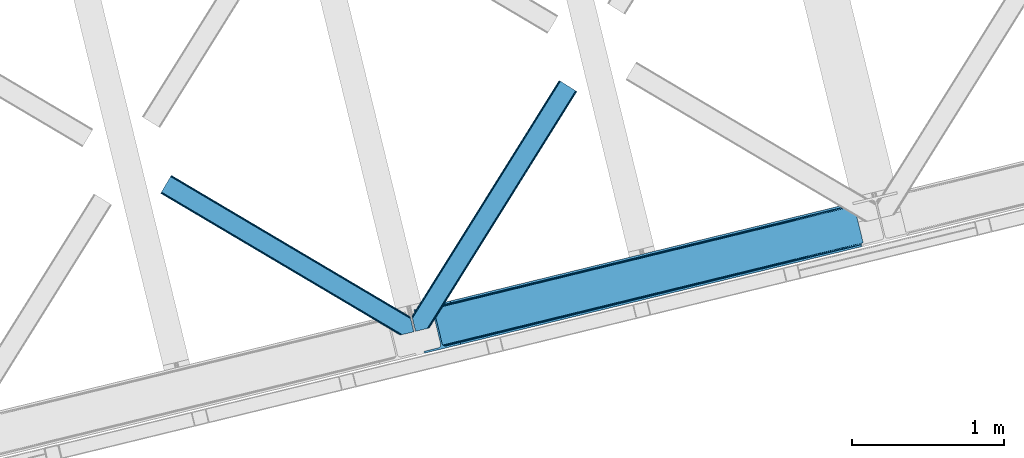
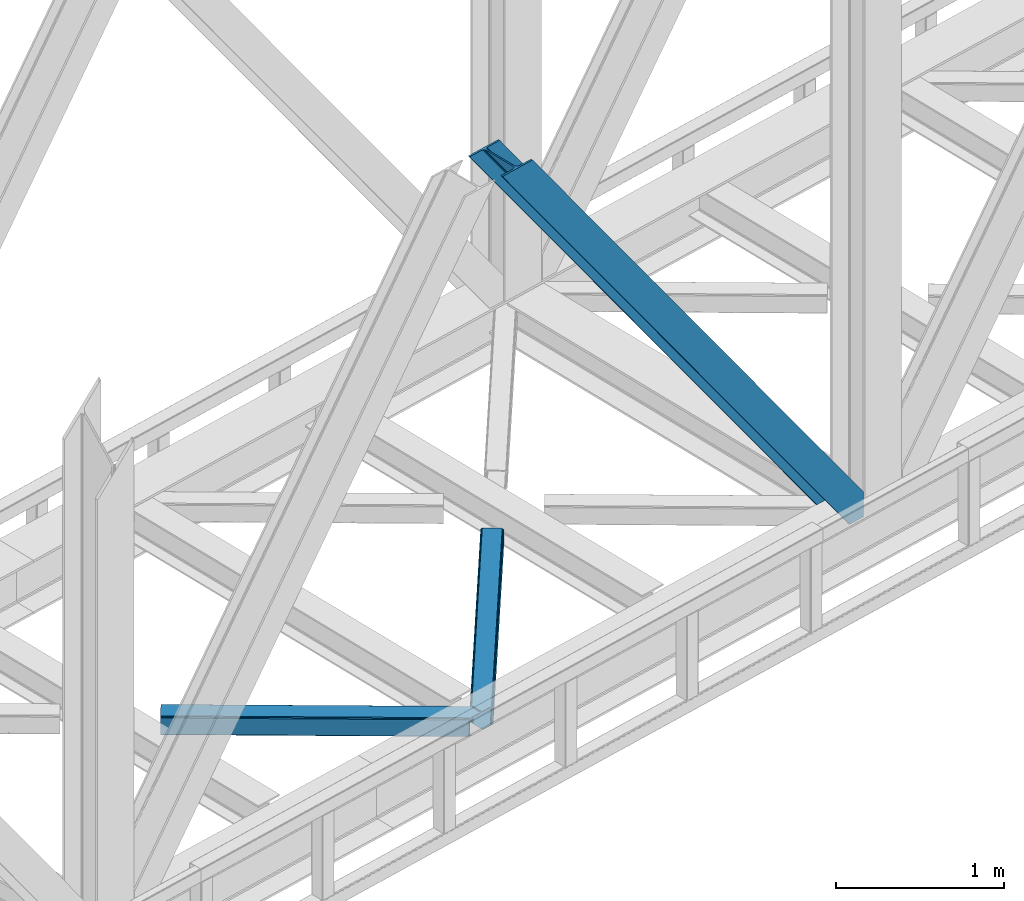
# One storey, part 65 of 92: 3 members.
"""IFC4 building model written with IfcOpenShell, lengths in millimetres."""

from ifc_helpers import new_model, entity, si_unit, converted_unit, derived_unit, direction, frame, origin, place, context, subcontext, project, spatial, triangles, type_object, element, save


model = new_model("IFC4")

# Units and contexts
model_context = context("Model", 3, precision=0.01, world=origin(), true_north=direction((6.12303176911189e-17, 1.0)))
plan_context = context("Plan", 3, precision=0.01, world=origin(), true_north=direction((6.12303176911189e-17, 1.0)))
body_context = subcontext(model_context, "Body", "Model", "MODEL_VIEW")
ifc_project = project(units=[si_unit("LENGTHUNIT", "METRE", prefix="MILLI"), si_unit("AREAUNIT", "SQUARE_METRE"), si_unit("VOLUMEUNIT", "CUBIC_METRE"), converted_unit("PLANEANGLEUNIT", "DEGREE", entity("IfcRatioMeasure", 0.0174532925199433), si_unit("PLANEANGLEUNIT", "RADIAN"), dimensions=[0, 0, 0, 0, 0, 0, 0]), si_unit("MASSUNIT", "GRAM", prefix="KILO"), derived_unit("MASSDENSITYUNIT", [(si_unit("MASSUNIT", "GRAM", prefix="KILO"), 1), (si_unit("LENGTHUNIT", "METRE"), -3)]), derived_unit("MOMENTOFINERTIAUNIT", [(si_unit("LENGTHUNIT", "METRE"), 4)]), si_unit("TIMEUNIT", "SECOND"), si_unit("FREQUENCYUNIT", "HERTZ"), si_unit("THERMODYNAMICTEMPERATUREUNIT", "DEGREE_CELSIUS"), derived_unit("THERMALTRANSMITTANCEUNIT", [(si_unit("MASSUNIT", "GRAM", prefix="KILO"), 1), (si_unit("THERMODYNAMICTEMPERATUREUNIT", "KELVIN"), -1), (si_unit("TIMEUNIT", "SECOND"), -3)]), derived_unit("VOLUMETRICFLOWRATEUNIT", [(si_unit("LENGTHUNIT", "METRE"), 3), (si_unit("TIMEUNIT", "SECOND"), -1)]), derived_unit("MASSFLOWRATEUNIT", [(si_unit("MASSUNIT", "GRAM", prefix="KILO"), 1), (si_unit("TIMEUNIT", "SECOND"), -1)]), derived_unit("ROTATIONALFREQUENCYUNIT", [(si_unit("TIMEUNIT", "SECOND"), -1)]), si_unit("ELECTRICCURRENTUNIT", "AMPERE"), si_unit("ELECTRICVOLTAGEUNIT", "VOLT"), si_unit("POWERUNIT", "WATT"), si_unit("FORCEUNIT", "NEWTON", prefix="KILO"), si_unit("ILLUMINANCEUNIT", "LUX"), si_unit("LUMINOUSFLUXUNIT", "LUMEN"), si_unit("LUMINOUSINTENSITYUNIT", "CANDELA"), derived_unit("USERDEFINED", [(si_unit("MASSUNIT", "GRAM", prefix="KILO"), -1), (si_unit("LENGTHUNIT", "METRE"), -2), (si_unit("TIMEUNIT", "SECOND"), 3), (si_unit("LUMINOUSFLUXUNIT", "LUMEN"), 1)]), derived_unit("LINEARVELOCITYUNIT", [(si_unit("LENGTHUNIT", "METRE"), 1), (si_unit("TIMEUNIT", "SECOND"), -1)]), si_unit("PRESSUREUNIT", "PASCAL"), derived_unit("USERDEFINED", [(si_unit("LENGTHUNIT", "METRE"), -2), (si_unit("MASSUNIT", "GRAM", prefix="KILO"), 1), (si_unit("TIMEUNIT", "SECOND"), -2)]), derived_unit("LINEARFORCEUNIT", [(si_unit("MASSUNIT", "GRAM", prefix="KILO"), 1), (si_unit("LENGTHUNIT", "METRE"), 1), (si_unit("TIMEUNIT", "SECOND"), -2), (si_unit("LENGTHUNIT", "METRE"), -1)]), derived_unit("PLANARFORCEUNIT", [(si_unit("MASSUNIT", "GRAM", prefix="KILO"), 1), (si_unit("LENGTHUNIT", "METRE"), 1), (si_unit("TIMEUNIT", "SECOND"), -2), (si_unit("LENGTHUNIT", "METRE"), -2)])], contexts=[model_context, plan_context])

# Site, building, storey
site_placement = place(None, origin())
site = spatial("IfcSite", under=ifc_project, at=site_placement, CompositionType="ELEMENT")
building_placement = place(site_placement, origin())
building = spatial("IfcBuilding", under=site, at=building_placement, CompositionType="ELEMENT")
storey_placement = place(building_placement, frame((0.0, 0.0, 15900.0)))
storey = spatial("IfcBuildingStorey", under=building, at=storey_placement, Name="05", CompositionType="ELEMENT", Elevation=15900.0)

# Members
member_type_1 = type_object("IfcMemberType", PredefinedType="BRACE")
member_1_placement = place(storey_placement, frame((-20226.16, 12536.45, 3695.0)))
element("IfcMember", 1, at=member_1_placement, inside=storey, type_object=member_type_1, ObjectType="Steel Vertical Brace", PredefinedType="BRACE", context=body_context, shape_type="Tessellation", body=[
    triangles([(2966.89216003418, 730.998403930664, 0.80925292968459), (2967.55374755859, 730.015905761718, 1.10690917968532), (2966.08058166504, 729.656625366211, 0.0), (2964.18534851074, 737.429406738282, 0.0), (2962.43778076172, 728.769470214844, 8.31577148437282), (2962.43778076172, 728.769470214844, 0.0), (2505.8586730957, 612.60679321289, 658.855133056641), (2511.36415100098, 609.932537841796, 662.301434326171), (2954.04410705566, 717.839904785156, 38.6743835449197), (2954.16851806641, 719.764205932617, 32.1678039550752), (2501.4112701416, 617.533236694337, 656.552947998047), (2958.54266967773, 726.957952880859, 14.8293273925774), (2955.07776489258, 722.243124389648, 26.1867736816384), (2955.64168395996, 723.796517944336, 22.4381652832017), (655.166986083983, 156.054428100586, 3289.34108276367), (649.44175415039, 156.069543457032, 3285.27854003906), (213.882293701172, 48.4865753173835, 3911.00081176758), (205.271191406249, 47.7982452392571, 3911.00081176758), (643.935113525389, 158.742636108398, 3281.83223876953), (197.320513916016, 49.8760253906257, 3911.00081176758), (639.488873291015, 163.67024230957, 3279.53005371094), (191.241815185545, 54.4048187255867, 3911.00081176758), (636.782061767579, 170.100082397461, 3278.7231262207), (187.962945556639, 60.6951324462898, 3911.00081176758), (2954.16037902832, 716.45859375, 50.6410949707024), (2517.08822021484, 609.917422485352, 666.36397705078), (2051.60733032227, 496.451092529296, 1322.10767211914), (2045.8832611084, 496.466207885742, 1318.04512939453), (1580.40353393555, 383.001040649415, 1973.78882446289), (1586.12760314941, 382.985925292969, 1977.85369262695), (1114.92264404297, 269.534710693359, 2629.53251953125), (1120.64671325684, 269.519595336915, 2633.59738769531), (2040.37778320312, 499.140463256836, 1314.598828125), (1574.89689331055, 385.675296020509, 1970.34484863281), (1109.41600341797, 272.208966064452, 2626.08854370117), (2035.93154296875, 504.066906738281, 1312.29896850586), (1570.45065307617, 390.601739501953, 1968.04266357422), (1104.96976318359, 277.135409545899, 2623.78635864258), (2498.70445861816, 623.963076782227, 655.74602050781), (2033.22473144531, 510.497909545898, 1311.48971557617), (1567.74384155273, 397.031579589844, 1967.23341064453), (1102.26295166016, 283.566412353515, 2622.97710571289), (2909.00499572754, 963.80047302246, 0.0), (2443.52410583496, 850.335305786133, 655.74602050781), (1978.04437866211, 736.868975830079, 1311.48971557617), (1512.56348876953, 623.40380859375, 1967.23341064453), (1047.08259887695, 509.937478637696, 2622.97710571289), (581.601708984374, 396.471148681641, 3278.7231262207), (132.782592773438, 287.067361450196, 3911.00081176758), (307.434722900391, 71.2909973144524, 3911.00081176758), (2954.16037902832, 716.45859375, 182.433050537107), (2954.3522277832, 715.476095581054, 0.0), (2954.16851806641, 719.764205932617, 0.0), (2954.3522277832, 715.476095581054, 182.495837402341), (2955.64168395996, 723.796517944336, 0.0), (2958.54266967773, 726.957952880859, 0.0), (2957.19391479492, 703.817504882813, 182.495837402341), (310.513604736327, 58.6603729248054, 3911.00081176758), (2957.19391479492, 703.817504882813, 0.0), (2846.09139404297, 676.734274291992, 0.0), (69.8631774902351, 0.0, 3911.00081176758), (2843.01251220703, 689.364898681641, 0.0), (66.7842956542954, 12.6294616699215, 3911.00081176758), (160.336724853514, 35.4338836669922, 3911.00081176758), (2936.56494140625, 712.169320678711, 0.0), (2953.96039123535, 734.936535644531, 0.0), (2953.94178771973, 727.841619873047, 0.0), (177.731011962889, 58.2010986328132, 3911.00081176758), (177.719384765624, 51.108508300782, 3911.00081176758), (2950.63036193847, 721.02459411621, 0.0), (174.403308105469, 44.2891571044929, 3911.00081176758), (2944.52840881348, 715.520278930664, 0.0), (168.299029541016, 38.7860046386722, 3911.00081176758), (2898.78003845215, 961.308764648438, 0.0), (122.550659179688, 284.573327636719, 3911.00081176758), (2872.85952758789, 973.517321777344, 0.0), (2881.47062988281, 974.205651855469, 0.0), (105.242413330077, 297.47021484375, 3911.00081176758), (96.6313110351548, 296.781884765625, 3911.00081176758), (2889.42130737305, 972.127871704102, 0.0), (113.19309082031, 295.392434692383, 3911.00081176758), (2895.49884338379, 967.599078369141, 0.0), (119.276440429687, 290.864804077148, 3911.00081176758), (3.07888183593604, 273.977462768555, 3911.00081176758), (2779.30709838867, 950.712899780274, 0.0), (2776.22821655273, 963.342361450195, 0.0), (0.0, 286.608087158203, 3911.00081176758), (142.21457519531, 306.482455444337, 3911.00081176758), (150.176879882813, 309.834576416015, 3911.00081176758), (136.110296630857, 300.979302978516, 3911.00081176758), (132.798870849609, 294.161114501952, 3911.00081176758), (240.650427246092, 345.268460083007, 3911.00081176758), (243.729309082031, 332.638998413086, 3911.00081176758), (2887.33073730469, 990.425592041016, 182.495837402341), (2887.33073730469, 990.425592041016, 0.0), (2890.45496520996, 977.805432128906, 182.433050537107), (2890.17242431641, 978.767001342774, 182.495837402341), (1522.42102661133, 644.332763671875, 1977.85369262695), (591.459246826173, 417.401266479492, 3289.34108276367), (1056.94013671875, 530.867596435546, 2633.59738769531), (1987.90191650391, 757.799093627929, 1322.10767211914), (2453.38164367676, 871.265423583984, 666.36397705078), (2890.45496520996, 977.805432128906, 50.6410949707024), (2890.17242431641, 978.767001342774, 0.0), (2890.986328125, 976.525277709961, 38.6743835449197), (2892.14904785156, 974.998626708984, 33.1630920410134), (2891.98277893066, 974.875378417968, 0.0), (2893.5687286377, 973.138275146484, 26.4425720214822), (2895.14653930664, 971.973229980469, 22.4381652832017), (2903.46812438965, 970.684936523438, 8.31577148437282), (2903.46812438965, 970.684936523438, 0.0), (2899.17652587891, 970.50122680664, 0.0), (2899.17652587891, 970.50122680664, 14.8293273925774), (2895.14653930664, 971.973229980469, 0.0), (2907.11092529297, 971.573254394531, 0.0), (2444.64961853027, 863.710070800782, 658.855133056641), (2442.96832580566, 857.289532470702, 656.552947998047), (2908.44921569824, 970.755862426759, 0.80925292968459), (2908.58409118652, 971.932534790039, 1.10690917968532), (581.045928955078, 403.426538085938, 3279.53005371094), (582.727221679688, 409.845913696288, 3281.83223876953), (586.385137939451, 414.753753662109, 3285.27854003906), (2448.30753479004, 868.617910766601, 662.301434326171), (1977.48859863281, 743.823202514648, 1312.29896850586), (1512.00770874024, 630.358035278321, 1968.04266357422), (1046.52681884765, 516.891705322265, 2623.78635864258), (1979.16872863769, 750.243740844726, 1314.598828125), (1513.68783874512, 636.778573608399, 1970.34484863281), (1048.20694885254, 523.312243652344, 2626.08854370117), (1982.82664489746, 755.151580810547, 1318.04512939453), (1517.34575500488, 641.686413574218, 1973.78882446289), (1051.8648651123, 528.220083618164, 2629.53251953125)], [[1, 2, 3], [3, 4, 1], [2, 5, 6], [6, 3, 2], [7, 8, 9], [9, 10, 7], [11, 12, 5], [5, 1, 11], [11, 7, 13], [13, 14, 11], [14, 12, 11], [15, 16, 17], [18, 17, 16], [16, 19, 18], [20, 18, 19], [19, 21, 20], [22, 20, 21], [21, 23, 22], [24, 22, 23], [5, 2, 1], [10, 13, 7], [25, 9, 8], [8, 26, 25], [26, 8, 27], [28, 27, 8], [27, 28, 29], [29, 30, 27], [30, 29, 31], [31, 32, 30], [32, 31, 16], [16, 15, 32], [8, 7, 33], [33, 28, 8], [28, 33, 29], [34, 29, 33], [29, 34, 31], [35, 31, 34], [31, 35, 16], [19, 16, 35], [7, 11, 33], [36, 33, 11], [33, 36, 34], [37, 34, 36], [34, 37, 35], [38, 35, 37], [35, 38, 21], [21, 19, 35], [1, 4, 39], [39, 11, 1], [11, 39, 40], [40, 36, 11], [36, 40, 41], [41, 37, 36], [37, 41, 42], [42, 38, 37], [38, 42, 23], [23, 21, 38], [4, 43, 44], [45, 39, 44], [41, 40, 45], [41, 45, 46], [44, 39, 4], [45, 40, 39], [42, 41, 46], [46, 47, 42], [47, 48, 23], [49, 24, 48], [47, 23, 42], [48, 24, 23], [50, 51, 30], [30, 32, 50], [32, 15, 50], [17, 50, 15], [27, 30, 51], [51, 25, 26], [26, 27, 51], [52, 9, 25], [52, 53, 10], [10, 9, 52], [25, 51, 54], [54, 52, 25], [14, 53, 55], [53, 14, 13], [10, 53, 13], [56, 12, 55], [14, 55, 12], [6, 5, 56], [12, 56, 5], [57, 54, 58], [54, 51, 50], [50, 58, 54], [57, 59, 52], [52, 54, 57], [58, 60, 57], [58, 61, 60], [60, 59, 57], [62, 60, 61], [61, 63, 62], [63, 64, 62], [65, 62, 64], [66, 67, 68], [69, 68, 67], [67, 70, 69], [71, 69, 70], [70, 72, 71], [73, 71, 72], [72, 65, 73], [64, 73, 65], [74, 66, 68], [68, 75, 74], [76, 77, 78], [78, 79, 76], [77, 80, 81], [81, 78, 77], [80, 82, 83], [83, 81, 80], [82, 74, 75], [75, 83, 82], [79, 84, 85], [85, 76, 79], [86, 85, 87], [84, 87, 85], [75, 68, 49], [71, 73, 18], [64, 61, 17], [63, 61, 64], [73, 64, 17], [68, 69, 22], [69, 71, 20], [81, 88, 78], [87, 79, 89], [79, 78, 89], [87, 84, 79], [81, 83, 90], [83, 75, 91], [49, 68, 24], [17, 18, 73], [22, 69, 20], [18, 20, 71], [22, 24, 68], [58, 17, 61], [58, 50, 17], [89, 78, 88], [90, 83, 91], [49, 91, 75], [90, 88, 81], [89, 92, 87], [92, 89, 93], [92, 86, 87], [86, 92, 94], [95, 86, 94], [96, 97, 93], [97, 94, 92], [92, 93, 97], [98, 96, 93], [93, 99, 100], [99, 93, 89], [100, 98, 93], [96, 98, 101], [101, 102, 96], [103, 96, 102], [97, 104, 94], [95, 94, 104], [104, 105, 106], [96, 103, 97], [104, 97, 103], [103, 105, 104], [107, 108, 109], [107, 106, 108], [110, 111, 112], [112, 113, 110], [113, 112, 114], [114, 109, 113], [109, 114, 107], [106, 107, 104], [53, 70, 55], [76, 86, 95], [85, 86, 76], [77, 76, 95], [104, 80, 77], [77, 95, 104], [104, 107, 80], [60, 65, 59], [52, 72, 70], [65, 72, 59], [60, 62, 65], [70, 53, 52], [52, 59, 72], [43, 66, 74], [82, 112, 74], [80, 114, 82], [80, 107, 114], [82, 114, 112], [111, 43, 74], [112, 111, 74], [43, 111, 115], [4, 66, 43], [56, 66, 6], [55, 70, 67], [67, 66, 56], [56, 55, 67], [4, 6, 66], [3, 6, 4], [116, 113, 109], [117, 118, 113], [113, 116, 117], [109, 108, 116], [118, 119, 110], [110, 113, 118], [48, 120, 91], [91, 49, 48], [120, 121, 90], [90, 91, 120], [121, 122, 88], [88, 90, 121], [122, 99, 89], [89, 88, 122], [105, 103, 123], [102, 123, 103], [106, 116, 108], [116, 106, 105], [123, 116, 105], [43, 118, 44], [117, 44, 118], [44, 117, 45], [124, 45, 117], [45, 124, 46], [125, 46, 124], [46, 125, 47], [126, 47, 125], [47, 126, 48], [120, 48, 126], [117, 116, 127], [127, 124, 117], [124, 127, 128], [128, 125, 124], [125, 128, 129], [129, 126, 125], [126, 129, 121], [121, 120, 126], [116, 123, 127], [130, 127, 123], [127, 130, 131], [131, 128, 127], [128, 131, 132], [132, 129, 128], [129, 132, 122], [122, 121, 129], [123, 102, 101], [101, 130, 123], [130, 101, 131], [98, 131, 101], [131, 98, 132], [100, 132, 98], [132, 100, 122], [99, 122, 100], [110, 119, 111], [115, 111, 119], [119, 118, 115], [43, 115, 118]]),
])
member_type_2 = type_object("IfcMemberType", PredefinedType="BRACE")
member_2_placement = place(storey_placement, frame((-20238.88, 12681.07, 3510.0)))
element("IfcMember", 2, at=member_2_placement, inside=storey, type_object=member_type_2, ObjectType="Steel Horizontal Brace", PredefinedType="BRACE", context=body_context, shape_type="Tessellation", body=[
    triangles([(986.150271606446, 1647.42851257324, 0.0), (1075.22041625977, 1591.8260925293, 0.0), (119.788037109374, 259.603921508789, 0.0), (154.548706054688, 117.003323364257, 0.0), (115.902227783205, 275.544808959961, 4.52065429687718), (117.571893310549, 268.698715209961, 1.33247680664135), (158.434515380861, 101.062435913085, 4.52065429687718), (156.767175292971, 107.908529663086, 1.33247680664135), (114.825549316407, 275.742471313477, 5.52059326172093), (115.130181884768, 275.922692871094, 5.35316162109666), (158.132208251955, 99.1218566894531, 5.27525939941552), (115.439465332031, 276.107565307617, 5.18107910156323), (158.236853027345, 99.7776306152336, 5.02062377929906), (158.188018798828, 99.4811370849602, 5.13573303222802), (115.54178466797, 276.166864013672, 5.12526855468968), (115.685961914063, 275.921530151367, 4.88574829101708), (158.339172363281, 100.434567260741, 4.76482543945531), (158.032214355469, 98.4928253173821, 5.52059326172093), (1085.71628723145, 1585.27300415039, 5.12526855468968), (1080.90495300293, 1588.28096008301, 1.33247680664135), (1088.93469543457, 1583.26498718262, 10.8028289794929), (114.209307861329, 21.8521545410149, 10.8028289794929), (109.470062255859, 20.6964111328125, 5.52059326172093), (1090.0695098877, 1582.56037902832, 17.5000946044929), (116.062683105469, 22.3044525146488, 17.5000946044929), (6.7507507324226, 102.618154907226, 5.52059326172093), (31.3608764648452, 1.65687561035156, 5.52059326172093), (1090.0695098877, 1582.56037902832, 122.500662231447), (116.062683105469, 22.3044525146488, 122.500662231447), (1088.93469543457, 1583.26498718262, 129.197927856447), (114.209307861329, 21.8521545410149, 129.197927856447), (1085.71628723145, 1585.27300415039, 134.874325561526), (108.935211181641, 20.5673492431633, 134.874325561526), (1080.90495300293, 1588.28096008301, 138.667117309571), (101.042669677736, 18.6430480957024, 138.667117309571), (1075.22041625977, 1591.8260925293, 139.999594116212), (91.7292846679702, 16.3722564697255, 139.999594116212), (980.470385742188, 1650.97480773926, 1.33247680664135), (975.654400634765, 1653.98160095215, 5.12526855468968), (1.68826904297021, 100.410150146485, 10.9621215820334), (972.435992431641, 1655.99078063965, 10.8028289794929), (971.306991577148, 1656.69655151367, 17.5000946044929), (0.239520263672603, 99.7776306152336, 12.5201660156272), (0.0, 100.760128784179, 17.5000946044929), (5.79266967773583, 76.992974853516, 139.999594116212), (986.150271606446, 1647.42851257324, 139.999594116212), (24.5612915039055, 0.0, 139.999594116212), (971.306991577148, 1656.69655151367, 122.500662231447), (0.0, 100.760128784179, 122.500662231447), (980.470385742188, 1650.97480773926, 138.667117309571), (3.57652587890698, 86.088931274413, 138.667117309571), (975.654400634765, 1653.98160095215, 134.874325561526), (1.69524536133031, 93.7989257812496, 134.874325561526), (972.435992431641, 1655.99078063965, 129.197927856447), (0.439508056642808, 98.9509368896488, 129.197927856447), (29.9237548828132, 1.30689697265552, 6.99957275390625), (12.1969299316406, 74.0326904296871, 6.99957275390625), (8.99479980468823, 81.5485107421864, 8.3320495605476), (3.88813476562427, 84.8111022949215, 12.5201660156272), (1069.28589477539, 1595.53400573731, 6.99957275390625), (81.9973205566421, 14.000308227538, 6.99957275390625), (992.090606689453, 1643.72176208496, 6.99957275390625), (981.593572998048, 1650.27485046387, 12.1260040283232), (978.375164794921, 1652.28403015137, 17.8035644531265), (2.75797119140771, 89.4445404052731, 17.8035644531265), (986.409558105468, 1647.2692199707, 8.3320495605476), (977.246163940432, 1652.98980102539, 24.4996673583992), (2.31613769531396, 91.2537322998051, 24.4996673583992), (977.246163940432, 1652.98980102539, 115.501089477541), (2.31613769531396, 91.2537322998051, 115.501089477541), (4.01370849609521, 84.2925292968739, 127.87475280762), (2.75797119140771, 89.4445404052731, 122.196029663086), (5.89266357422093, 76.5813720703118, 131.667544555665), (8.11113281250073, 67.4865783691403, 133.000021362306), (24.5612915039055, 0.0, 133.000021362306), (978.375164794921, 1652.28403015137, 122.196029663086), (981.593572998048, 1650.27485046387, 127.87475280762), (986.409558105468, 1647.2692199707, 131.667544555665), (992.090606689453, 1643.72176208496, 133.000021362306), (1069.28589477539, 1595.53400573731, 133.000021362306), (81.9973205566421, 14.000308227538, 133.000021362306), (1079.78176574707, 1588.9809173584, 12.1260040283232), (1083.0001739502, 1586.9717376709, 17.8035644531265), (1084.12917480469, 1586.2671295166, 24.4996673583992), (1074.96578063965, 1591.98771057129, 8.3320495605476), (1079.78176574707, 1588.9809173584, 127.87475280762), (1084.12917480469, 1586.2671295166, 115.501089477541), (1083.0001739502, 1586.9717376709, 122.196029663086), (1074.96578063965, 1591.98771057129, 131.667544555665), (91.3083801269531, 16.2699371337894, 131.667544555665), (99.2032470703125, 18.1942382812504, 127.87475280762), (104.477343750001, 19.4802062988274, 122.196029663086), (106.32839355469, 19.931341552734, 115.501089477541), (91.3083801269531, 16.2699371337894, 8.3320495605476), (104.477343750001, 19.4802062988274, 17.8035644531265), (99.2032470703125, 18.1942382812504, 12.1260040283232), (106.32839355469, 19.931341552734, 24.4996673583992)], [[1, 2, 3], [4, 3, 2], [5, 3, 4], [3, 5, 6], [4, 7, 5], [7, 4, 8], [9, 10, 11], [10, 12, 13], [13, 14, 10], [12, 15, 16], [16, 17, 12], [16, 5, 7], [7, 17, 16], [17, 13, 12], [14, 11, 10], [11, 18, 9], [19, 14, 13], [13, 20, 19], [13, 17, 20], [17, 7, 20], [7, 8, 20], [21, 22, 18], [18, 19, 21], [14, 19, 11], [18, 11, 19], [22, 23, 18], [21, 24, 25], [25, 22, 21], [2, 20, 4], [8, 4, 20], [23, 26, 18], [23, 27, 26], [9, 18, 26], [24, 28, 29], [29, 25, 24], [28, 30, 29], [31, 29, 30], [30, 32, 31], [33, 31, 32], [32, 34, 33], [35, 33, 34], [34, 36, 35], [37, 35, 36], [38, 6, 5], [5, 39, 38], [5, 15, 39], [40, 41, 9], [41, 39, 15], [42, 41, 40], [40, 43, 42], [43, 44, 42], [9, 26, 40], [38, 1, 6], [3, 6, 1], [36, 45, 37], [36, 46, 45], [45, 47, 37], [48, 42, 44], [44, 49, 48], [46, 50, 51], [51, 45, 46], [50, 52, 53], [53, 51, 50], [52, 54, 55], [55, 53, 52], [54, 48, 49], [49, 55, 54], [27, 56, 57], [26, 57, 58], [57, 26, 27], [59, 40, 26], [26, 58, 59], [43, 40, 59], [60, 57, 61], [60, 62, 57], [57, 56, 61], [63, 64, 65], [65, 59, 63], [66, 63, 59], [62, 66, 58], [58, 57, 62], [59, 58, 66], [64, 67, 68], [68, 65, 64], [67, 69, 68], [70, 68, 69], [71, 53, 72], [73, 74, 45], [74, 47, 45], [74, 75, 47], [51, 73, 45], [71, 51, 53], [71, 73, 51], [49, 68, 70], [55, 72, 53], [70, 72, 49], [72, 55, 49], [44, 68, 49], [43, 59, 65], [65, 68, 44], [44, 43, 65], [69, 76, 70], [72, 70, 76], [76, 77, 72], [71, 72, 77], [77, 78, 71], [73, 71, 78], [78, 79, 73], [74, 73, 79], [80, 74, 79], [74, 80, 81], [75, 74, 81], [21, 82, 83], [84, 28, 24], [21, 83, 24], [21, 19, 82], [83, 84, 24], [82, 19, 20], [60, 2, 1], [2, 85, 20], [85, 2, 60], [85, 82, 20], [30, 86, 32], [87, 28, 84], [28, 88, 30], [88, 28, 87], [30, 88, 86], [36, 80, 46], [34, 32, 86], [86, 89, 34], [89, 80, 36], [36, 34, 89], [63, 38, 39], [1, 62, 60], [1, 66, 62], [66, 1, 38], [63, 66, 38], [67, 42, 48], [41, 64, 63], [39, 41, 63], [64, 41, 42], [67, 64, 42], [50, 77, 52], [46, 80, 79], [79, 78, 46], [78, 77, 50], [50, 46, 78], [54, 52, 77], [48, 69, 67], [76, 48, 54], [48, 76, 69], [76, 54, 77], [35, 37, 90], [47, 81, 37], [81, 47, 75], [81, 90, 37], [91, 35, 90], [91, 33, 35], [33, 92, 31], [92, 33, 91], [29, 92, 93], [92, 29, 31], [61, 23, 94], [95, 96, 23], [96, 94, 23], [61, 27, 23], [27, 61, 56], [97, 95, 25], [22, 25, 95], [29, 97, 25], [97, 29, 93], [95, 23, 22], [80, 89, 90], [90, 81, 80], [89, 86, 91], [91, 90, 89], [86, 88, 92], [92, 91, 86], [88, 87, 93], [93, 92, 88], [87, 84, 97], [97, 93, 87], [84, 83, 97], [95, 97, 83], [83, 82, 95], [96, 95, 82], [82, 85, 96], [94, 96, 85], [85, 60, 94], [61, 94, 60]]),
])
member_type_3 = type_object("IfcMemberType", PredefinedType="BRACE")
member_3_placement = place(storey_placement, frame((-21897.52, 12655.92, 3510.0)))
element("IfcMember", 3, at=member_3_placement, inside=storey, type_object=member_type_3, ObjectType="Steel Horizontal Brace", PredefinedType="BRACE", context=body_context, shape_type="Tessellation", body=[
    triangles([(1467.52902832031, 208.965151977538, 0.0), (1502.28969726562, 66.3657165527329, 0.0), (8.91573486327979, 950.478030395507, 0.0), (62.405493164064, 1040.83065490723, 0.0), (0.679028320311772, 936.564926147461, 10.8028289794929), (1582.26156005859, 0.541827392577034, 10.8679412841811), (1580.03843994141, 0.0, 17.5000946044929), (1508.64744873047, 44.5007720947251, 9.52034912109593), (2.6114685058601, 939.829843139647, 5.12526855468968), (1506.38479614258, 49.5597656249993, 5.12526855468968), (1507.26148681641, 45.9657989501939, 8.52041015625218), (1508.31258544922, 44.8554016113267, 9.27850341796875), (1507.95214233398, 45.2332855224595, 9.02037963867406), (1507.59635009766, 45.6123321533196, 8.76225585937573), (1582.7126953125, 0.651123046875, 9.52034912109593), (1504.50584106445, 57.2697601318359, 1.33247680664135), (5.50431518554615, 944.715591430664, 1.33247680664135), (0.0, 935.41848449707, 17.5000946044929), (1580.03843994141, 0.0, 122.500662231447), (0.0, 935.41848449707, 122.500662231447), (1595.05845336914, 3.66024169921729, 138.667117309571), (1604.36951293945, 5.93103332519422, 139.999594116212), (8.91573486327979, 950.478030395507, 139.999594116212), (5.50431518554615, 944.715591430664, 138.667117309571), (1587.16358642578, 1.73710327148365, 134.874325561526), (2.6114685058601, 939.829843139647, 134.874325561526), (1581.88948974609, 0.451135253904795, 129.197927856447), (0.679028320311772, 936.564926147461, 129.197927856447), (1502.33388061524, 66.183169555663, 8.52041015625218), (1502.68967285156, 65.0390533447262, 8.90294494629052), (1503.18034057617, 64.3204925537102, 9.10758361816625), (1503.67798461914, 63.5914672851559, 9.31571044922021), (1504.1709777832, 62.8729064941399, 9.52034912109593), (1601.52317504883, 5.23688964843677, 9.52034912109593), (9.07153930664208, 950.739642333983, 8.3320495605476), (1502.18272705078, 66.8063873291012, 8.42274169922166), (6.1786926269524, 945.853894042968, 12.1260040283232), (1596.89555053711, 4.10905151367115, 12.1260040283232), (1499.97123413086, 75.8721130371086, 6.99957275390625), (12.4829589843757, 956.502081298828, 6.99957275390625), (1591.62377929688, 2.82424621581958, 17.8035644531265), (4.24625244140771, 942.58897705078, 17.8035644531265), (1589.77040405274, 2.3719482421875, 24.4996673583992), (3.56722412109229, 941.442535400391, 24.4996673583992), (1469.84749145508, 199.458755493164, 6.99957275390625), (58.8429199218735, 1034.80776672363, 6.99957275390625), (1462.55723876953, 229.365069580077, 8.52041015625218), (1467.4848449707, 209.147698974608, 8.52041015625218), (1463.4316040039, 225.771102905273, 5.12526855468968), (1467.63599853516, 208.524481201172, 8.42274169922166), (1465.31288452149, 218.061108398437, 1.33247680664135), (1589.77040405274, 2.3719482421875, 115.501089477541), (3.56722412109229, 941.442535400391, 115.501089477541), (1591.62377929688, 2.82424621581958, 122.196029663086), (4.24625244140771, 942.58897705078, 122.196029663086), (1596.89555053711, 4.10905151367115, 127.87475280762), (6.1786926269524, 945.853894042968, 127.87475280762), (1604.79041748047, 6.03335266113208, 131.667544555665), (9.07153930664208, 950.739642333983, 131.667544555665), (1614.10380249023, 8.30298156738172, 133.000021362306), (12.4829589843757, 956.502081298828, 133.000021362306), (1671.53983154297, 22.304452514647, 139.999594116212), (1671.53983154297, 22.304452514647, 133.000021362306), (1652.7712097168, 99.297427368163, 139.999594116212), (62.405493164064, 1040.83065490723, 139.999594116212), (1655.08734741211, 89.7910308837891, 133.000021362306), (58.8429199218735, 1034.80776672363, 133.000021362306), (1647.4180480957, 121.255389404296, 129.197927856447), (1646.97854003906, 123.064581298828, 122.500662231447), (70.642199707032, 1054.74375915527, 129.197927856447), (71.3258789062493, 1055.89020080566, 122.500662231447), (1648.67378540039, 116.103378295898, 134.874325561526), (68.7144104003892, 1051.48000488281, 134.874325561526), (1650.55274047852, 108.393383789062, 138.667117309571), (65.8215637207031, 1046.5942565918, 138.667117309571), (1646.97854003906, 123.064581298828, 17.5000946044929), (71.3258789062493, 1055.89020080566, 17.5000946044929), (70.642199707032, 1054.74375915527, 10.8028289794929), (65.1471862792969, 1045.45595397949, 12.1260040283232), (67.0796264648452, 1048.72087097168, 17.8035644531265), (67.7563293457024, 1049.86731262207, 24.4996673583992), (68.7144104003892, 1051.48000488281, 5.12526855468968), (65.8215637207031, 1046.5942565918, 1.33247680664135), (62.2543395996108, 1040.57020568848, 8.3320495605476), (65.1471862792969, 1045.45595397949, 127.87475280762), (67.7563293457024, 1049.86731262207, 115.501089477541), (67.0796264648452, 1048.72087097168, 122.196029663086), (62.2543395996108, 1040.57020568848, 131.667544555665), (1649.29467773438, 113.558184814452, 24.4996673583992), (1649.29467773438, 113.558184814452, 115.501089477541), (1652.87120361328, 98.8858245849606, 131.667544555665), (1650.99224853516, 106.596981811523, 127.87475280762), (1649.73651123047, 111.748992919922, 122.196029663086), (1649.82487792969, 111.385061645507, 17.8686767578147), (1649.93184814453, 110.943228149414, 16.5199218750022), (1646.98551635742, 123.027374267578, 16.5199218750022), (1640.69752807617, 124.970278930663, 10.8702667236357), (1462.77583007812, 229.699932861327, 9.22734375000073), (1462.66420898437, 229.532501220703, 8.87387695312646), (1463.57578125, 229.405764770507, 9.52034912109593), (1639.19529418945, 125.435366821288, 9.52034912109593), (1645.70419921875, 109.725860595703, 12.1260040283232), (1468.05457763672, 211.033630371094, 9.52034912109593), (1643.67409057617, 107.063232421875, 9.52034912109593)], [[1, 2, 3], [3, 4, 1], [5, 6, 7], [6, 5, 8], [5, 9, 10], [10, 11, 5], [12, 5, 13], [12, 8, 5], [5, 14, 13], [5, 11, 14], [8, 15, 6], [16, 10, 9], [9, 17, 16], [2, 16, 17], [17, 3, 2], [7, 18, 5], [7, 19, 18], [20, 18, 19], [21, 22, 23], [23, 24, 21], [25, 21, 24], [24, 26, 25], [27, 25, 26], [26, 28, 27], [19, 27, 28], [28, 20, 19], [11, 29, 30], [14, 30, 31], [13, 31, 32], [12, 32, 33], [33, 8, 12], [32, 12, 13], [31, 13, 14], [30, 14, 11], [34, 15, 33], [8, 33, 15], [35, 30, 29], [32, 35, 33], [35, 32, 31], [30, 35, 31], [29, 36, 35], [37, 38, 33], [33, 35, 37], [38, 34, 33], [35, 36, 39], [39, 40, 35], [41, 38, 37], [37, 42, 41], [43, 41, 42], [42, 44, 43], [39, 45, 40], [46, 40, 45], [1, 45, 39], [47, 48, 49], [48, 50, 1], [45, 1, 50], [48, 51, 49], [48, 1, 51], [2, 1, 39], [2, 39, 36], [29, 2, 36], [11, 10, 29], [29, 16, 2], [29, 10, 16], [52, 43, 44], [44, 53, 52], [54, 52, 55], [53, 55, 52], [56, 54, 57], [55, 57, 54], [58, 56, 59], [57, 59, 56], [60, 58, 61], [59, 61, 58], [56, 58, 21], [25, 56, 21], [25, 27, 54], [56, 25, 54], [54, 27, 19], [58, 22, 21], [62, 60, 63], [62, 22, 60], [58, 60, 22], [54, 19, 52], [43, 7, 41], [19, 43, 52], [7, 6, 41], [19, 7, 43], [15, 41, 6], [38, 41, 15], [34, 38, 15], [22, 64, 23], [22, 62, 64], [65, 23, 64], [66, 60, 61], [60, 66, 63], [61, 67, 66], [68, 69, 70], [71, 70, 69], [72, 68, 73], [70, 73, 68], [74, 72, 75], [73, 75, 72], [64, 74, 65], [75, 65, 74], [69, 76, 71], [77, 71, 76], [78, 79, 80], [81, 71, 77], [78, 80, 77], [78, 82, 79], [80, 81, 77], [79, 82, 83], [46, 4, 3], [4, 84, 83], [84, 4, 46], [84, 79, 83], [70, 85, 73], [86, 71, 81], [71, 87, 70], [87, 71, 86], [70, 87, 85], [65, 67, 23], [75, 73, 85], [85, 88, 75], [88, 67, 65], [65, 75, 88], [37, 17, 9], [3, 40, 46], [3, 35, 40], [35, 3, 17], [37, 35, 17], [44, 18, 20], [5, 42, 37], [9, 5, 37], [42, 5, 18], [44, 42, 18], [24, 57, 26], [23, 67, 61], [61, 59, 23], [59, 57, 24], [24, 23, 59], [28, 26, 57], [20, 53, 44], [55, 20, 28], [20, 55, 53], [55, 28, 57], [89, 90, 81], [86, 81, 90], [91, 66, 67], [67, 88, 91], [92, 91, 88], [88, 85, 92], [93, 92, 85], [85, 87, 93], [90, 93, 87], [87, 86, 90], [92, 72, 74], [66, 91, 64], [91, 92, 74], [94, 95, 96], [63, 66, 62], [64, 62, 66], [91, 74, 64], [94, 76, 89], [69, 90, 89], [89, 76, 69], [94, 96, 76], [69, 93, 90], [93, 72, 92], [72, 93, 68], [69, 68, 93], [77, 76, 97], [76, 96, 97], [98, 99, 82], [47, 82, 99], [47, 49, 82], [78, 97, 100], [100, 82, 78], [100, 98, 82], [97, 101, 100], [51, 1, 4], [4, 83, 51], [49, 51, 83], [83, 82, 49], [97, 78, 77], [80, 79, 102], [102, 95, 80], [80, 94, 89], [46, 45, 50], [103, 102, 79], [103, 104, 102], [50, 79, 84], [50, 103, 79], [50, 84, 46], [89, 81, 80], [95, 94, 80], [96, 102, 97], [102, 96, 95], [102, 101, 97], [102, 104, 101], [101, 104, 103], [103, 100, 101]]),
])

save(model, "model.ifc")
